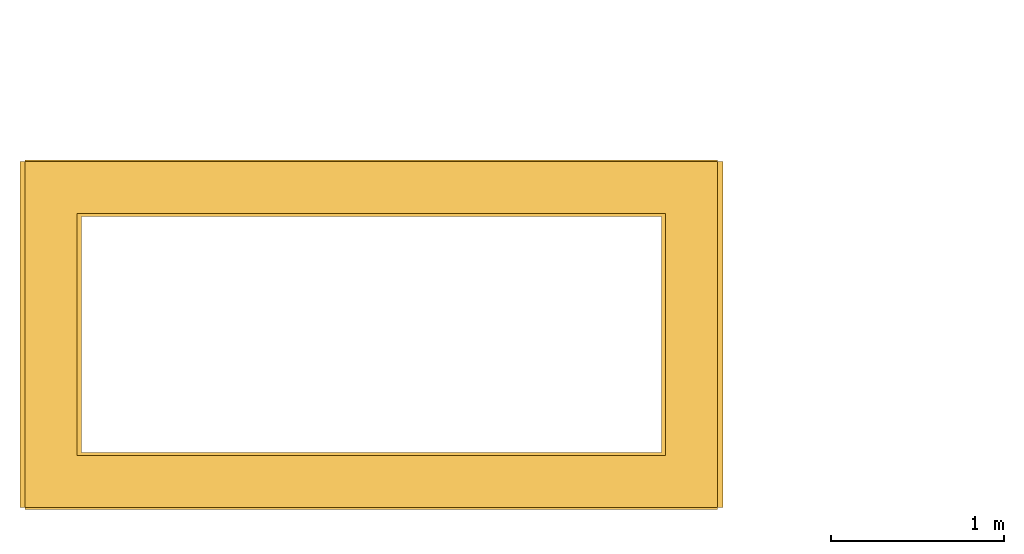
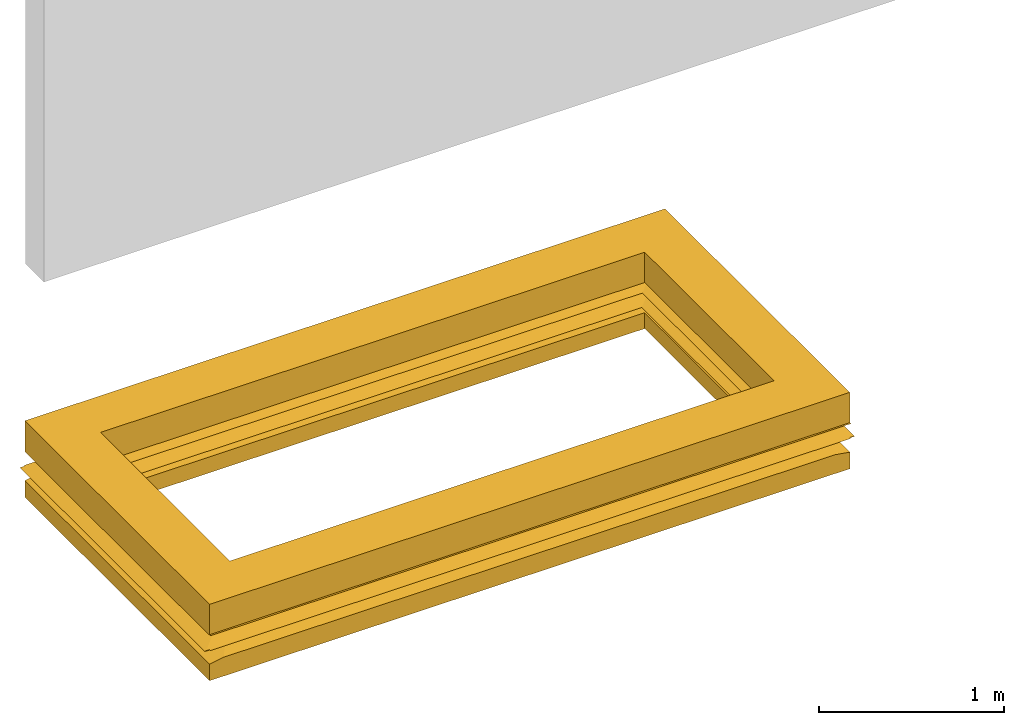
# One storey, part 2 of 2: 1 door.
"""IFC2X3 building model written with IfcOpenShell, lengths in millimetres."""

from ifc_helpers import new_model, entity, si_unit, converted_unit, derived_unit, direction, frame, origin, place, context, subcontext, project, spatial, faceted_brep, source, transform, mapped, material, material_list, type_object, type_shapes, element, save


model = new_model("IFC2X3")

# Units and contexts
model_context = context("Model", 3, precision=0.01, world=origin(), true_north=direction((6.12303176911189e-17, 1.0)))
context_of_model = context(None, 3, precision=0.01, world=origin(), true_north=direction((6.12303176911189e-17, 1.0)))
body_context = subcontext(model_context, "Body", "Model", "MODEL_VIEW")
ifc_project = project(units=[si_unit("LENGTHUNIT", "METRE", prefix="MILLI"), si_unit("AREAUNIT", "SQUARE_METRE"), si_unit("VOLUMEUNIT", "CUBIC_METRE"), converted_unit("PLANEANGLEUNIT", "DEGREE", entity("IfcRatioMeasure", 0.0174532925199433), si_unit("PLANEANGLEUNIT", "RADIAN"), dimensions=[0, 0, 0, 0, 0, 0, 0]), si_unit("MASSUNIT", "GRAM", prefix="KILO"), si_unit("TIMEUNIT", "SECOND"), si_unit("FREQUENCYUNIT", "HERTZ"), si_unit("THERMODYNAMICTEMPERATUREUNIT", "DEGREE_CELSIUS"), derived_unit("THERMALTRANSMITTANCEUNIT", [(si_unit("MASSUNIT", "GRAM", prefix="KILO"), 1), (si_unit("THERMODYNAMICTEMPERATUREUNIT", "KELVIN"), -1), (si_unit("TIMEUNIT", "SECOND"), -3)]), derived_unit("VOLUMETRICFLOWRATEUNIT", [(si_unit("LENGTHUNIT", "METRE"), 3), (si_unit("TIMEUNIT", "SECOND"), -1)]), si_unit("ELECTRICCURRENTUNIT", "AMPERE"), si_unit("ELECTRICVOLTAGEUNIT", "VOLT"), si_unit("POWERUNIT", "WATT"), si_unit("FORCEUNIT", "NEWTON", prefix="KILO"), si_unit("ILLUMINANCEUNIT", "LUX"), si_unit("LUMINOUSFLUXUNIT", "LUMEN"), si_unit("LUMINOUSINTENSITYUNIT", "CANDELA"), si_unit("PRESSUREUNIT", "PASCAL")], contexts=[model_context, context_of_model])

# Site, building, storey
site_placement = place(None, origin())
site = spatial("IfcSite", under=ifc_project, at=site_placement, CompositionType="ELEMENT")
building_placement = place(site_placement, origin())
building = spatial("IfcBuilding", under=site, at=building_placement, CompositionType="ELEMENT")
storey_placement = place(building_placement, origin())
storey = spatial("IfcBuildingStorey", under=building, at=storey_placement, CompositionType="ELEMENT", Elevation=0.0)

# Door
ifc_material_1 = material()
ifc_material_2 = material()
ifc_material_list_1 = material_list([ifc_material_1, ifc_material_2])
ifc_material_list_2 = material_list([ifc_material_1, ifc_material_2])
door_style = type_object("IfcDoorStyle", ConstructionType="NOTDEFINED", OperationType="NOTDEFINED", ParameterTakesPrecedence=False, Sizeable=False, material=ifc_material_list_2)
shared_shape = source(origin(), body_context, "Body", "Brep", [
    faceted_brep([(2000.0, -1000.0, 201.422542318932), (2000.0, -1000.0, 198.592852555135), (2021.55711533069, -1000.0, 198.592852555135), (2030.0, -1000.0, 200.0), (2021.46474608651, -1000.0, 201.422542318932), (-1910.0, 1000.0, 120.0), (1910.0, 1000.0, 120.0), (2000.0, 1000.0, 105.0), (2000.0, 1000.0, 100.0), (-2000.0, 1000.0, 100.0), (-2000.0, 1000.0, 105.0), (-2000.0, -1000.0, 198.592852555135), (-2000.0, -1008.44288466903, 200.0), (-2000.0, -1000.0, 201.422542318932), (2000.0, -1000.0, 100.0), (-2000.0, -1000.0, 100.0), (-1975.0, -988.936713263735, 100.0), (1975.0, -988.936713263745, 100.0), (1975.0, 988.936713263952, 100.0), (-1975.0, 988.936713263952, 100.0), (-1675.0, -688.936713263763, 150.0), (-1675.0, 688.936713264251, 150.0), (-1975.0, -978.442884669021, 200.0), (-1975.0, 978.442884668498, 200.0), (-1675.0, -681.689510216656, 250.0), (-1675.0, 681.689510216986, 250.0), (-1975.0, -981.689510217098, 300.0), (-1975.0, 981.689510216905, 300.0), (-2000.0, -1011.68951021689, 300.0), (2000.0, -1011.68951021689, 300.0), (2000.0, 999.772196685506, 300.0), (-2000.0, 999.772196685505, 300.0), (1975.0, -981.689510216891, 300.0), (1975.0, 981.689510216618, 300.0), (-2000.0, -981.68951021715, 295.0), (-2000.0, 981.689510216956, 295.0), (-1730.0, 711.689510216966, 250.0), (-1730.0, -711.689510217181, 250.0), (-2030.0, 1000.0, 200.0), (-2030.0, -1000.0, 200.0), (-2021.46474608623, -1000.0, 201.422542318932), (-2021.46474608568, 1000.0, 201.422542319024), (-2021.55711533152, 1000.0, 198.592852555226), (-1730.0, 708.442884668662, 150.0), (-1730.0, -708.442884669058, 150.0), (-2021.55711533097, -1000.0, 198.592852555135), (-2000.0, -1000.0, 105.0), (-1910.0, -1000.0, 120.0), (2000.0, 1000.0, 198.592852555226), (2000.0, 1008.44288466904, 200.0), (2000.0, 1000.0, 201.422542319024), (1910.0, -1000.0, 120.0), (1730.0, -708.44288466873, 150.0), (1675.0, -688.936713263756, 150.0), (1975.0, -978.442884669033, 200.0), (1675.0, -681.689510216893, 250.0), (1730.0, -711.68951021704, 250.0), (2000.0, -981.689510217158, 295.0), (2000.0, -1008.44288466903, 200.0), (1675.0, 688.936713264088, 150.0), (1975.0, 978.442884668767, 200.0), (1675.0, 681.689510217152, 250.0), (2000.0, 981.689510216963, 295.0), (1730.0, 711.689510216825, 250.0), (2030.0, 1000.0, 200.0), (2021.46474608595, 1000.0, 201.422542319024), (1730.0, 708.442884668864, 150.0), (2021.55711533123, 1000.0, 198.592852555226), (2000.0, -1000.0, 105.0), (-2000.0, 999.772196685505, 298.013781078098), (2000.0, 999.772196685505, 298.013781078098), (-2000.0, 1008.44288466904, 200.0), (-2000.0, 1000.0, 201.422542319024), (-2000.0, 1000.0, 198.592852555226)], [[[0, 1, 2, 3, 4]], [[5, 6, 7, 8, 9, 10]], [[11, 12, 13]], [[14, 15, 9, 8], [16, 17, 18, 19]], [[20, 16, 19, 21]], [[22, 20, 21, 23]], [[24, 22, 23, 25]], [[26, 24, 25, 27]], [[28, 29, 30, 31], [32, 26, 27, 33]], [[34, 35, 36, 37]], [[38, 39, 40, 37, 36, 41]], [[39, 38, 42, 43, 44, 45]], [[10, 46, 47, 44, 43, 5]], [[48, 49, 50]], [[51, 52, 44, 47]], [[16, 20, 53, 17]], [[20, 22, 54, 53]], [[22, 24, 55, 54]], [[24, 26, 32, 55]], [[29, 28, 34, 37, 56, 57]], [[12, 58, 0, 4, 56, 37, 40, 13]], [[58, 12, 11, 45, 44, 52, 2, 1]], [[17, 53, 59, 18]], [[53, 54, 60, 59]], [[54, 55, 61, 60]], [[55, 32, 33, 61]], [[62, 57, 56, 63]], [[3, 64, 65, 63, 56, 4]], [[64, 3, 2, 52, 66, 67]], [[68, 7, 6, 66, 52, 51]], [[5, 43, 66, 6]], [[19, 18, 59, 21]], [[21, 59, 60, 23]], [[23, 60, 61, 25]], [[25, 61, 33, 27]], [[36, 35, 69, 70, 62, 63]], [[49, 71, 72, 41, 36, 63, 65, 50]], [[71, 49, 48, 67, 66, 43, 42, 73]], [[70, 69, 31, 30]], [[14, 8, 7, 68]], [[0, 58, 1]], [[29, 57, 62, 70, 30]], [[34, 28, 31, 69, 35]], [[72, 71, 73]], [[9, 15, 46, 10]], [[48, 50, 65, 64, 67]], [[72, 73, 42, 38, 41]], [[11, 13, 40, 39, 45]], [[51, 47, 46, 15, 14, 68]]]),
    faceted_brep([(-2000.0, -1000.0, 100.0), (2000.0, -1000.0, 100.0), (2000.0, 1000.0, 100.0), (-2000.0, 1000.0, 100.0), (-1700.0, -700.0, 100.0), (-1700.0, 700.0, 100.0), (1700.0, 700.0, 100.0), (1700.0, -700.0, 100.0), (-2000.0, -1000.0, -4.68773868510973), (-2000.0, 1000.0, -4.68773868510973), (2000.0, 1000.0, -4.68773868510973), (2000.0, -1000.0, -4.68773868510973), (-1700.0, -700.0, -4.68773868510973), (1700.0, -700.0, -4.68773868510973), (1700.0, 700.0, -4.68773868510973), (-1700.0, 700.0, -4.68773868510973)], [[[0, 1, 2, 3], [4, 5, 6, 7]], [[8, 9, 10, 11], [12, 13, 14, 15]], [[1, 0, 8, 11]], [[2, 1, 11, 10]], [[3, 2, 10, 9]], [[0, 3, 9, 8]], [[5, 4, 12, 15]], [[6, 5, 15, 14]], [[7, 6, 14, 13]], [[4, 7, 13, 12]]]),
    faceted_brep([(-2000.0, -1000.0, 500.0), (2000.0, -1000.0, 500.0), (2000.0, 1000.0, 500.0), (-2000.0, 1000.0, 500.0), (-1700.0, -700.0, 500.0), (-1700.0, 700.0, 500.0), (1700.0, 700.0, 500.0), (1700.0, -700.0, 500.0), (-2000.0, -1000.0, 300.0), (-2000.0, 1000.0, 300.0), (2000.0, 1000.0, 300.0), (2000.0, -1000.0, 300.0), (-1700.0, -700.0, 300.0), (1700.0, -700.0, 300.0), (1700.0, 700.0, 300.0), (-1700.0, 700.0, 300.0)], [[[0, 1, 2, 3], [4, 5, 6, 7]], [[8, 9, 10, 11], [12, 13, 14, 15]], [[1, 0, 8, 11]], [[2, 1, 11, 10]], [[3, 2, 10, 9]], [[0, 3, 9, 8]], [[5, 4, 12, 15]], [[6, 5, 15, 14]], [[7, 6, 14, 13]], [[4, 7, 13, 12]]]),
])
type_shapes(door_style, [shared_shape])
door_placement = place(storey_placement, frame((-29247.0958388037, 7247.08265900799, 0.0)))
element("IfcDoor", 1, at=door_placement, inside=storey, type_object=door_style, material=ifc_material_list_1, OverallHeight=504.687738685115, OverallWidth=4199.99999999999, context=body_context, shape_type="MappedRepresentation", body=[
    mapped(shared_shape, transform((0.0, 0.0, 0.0), scale=1.0)),
])

save(model, "model.ifc")
